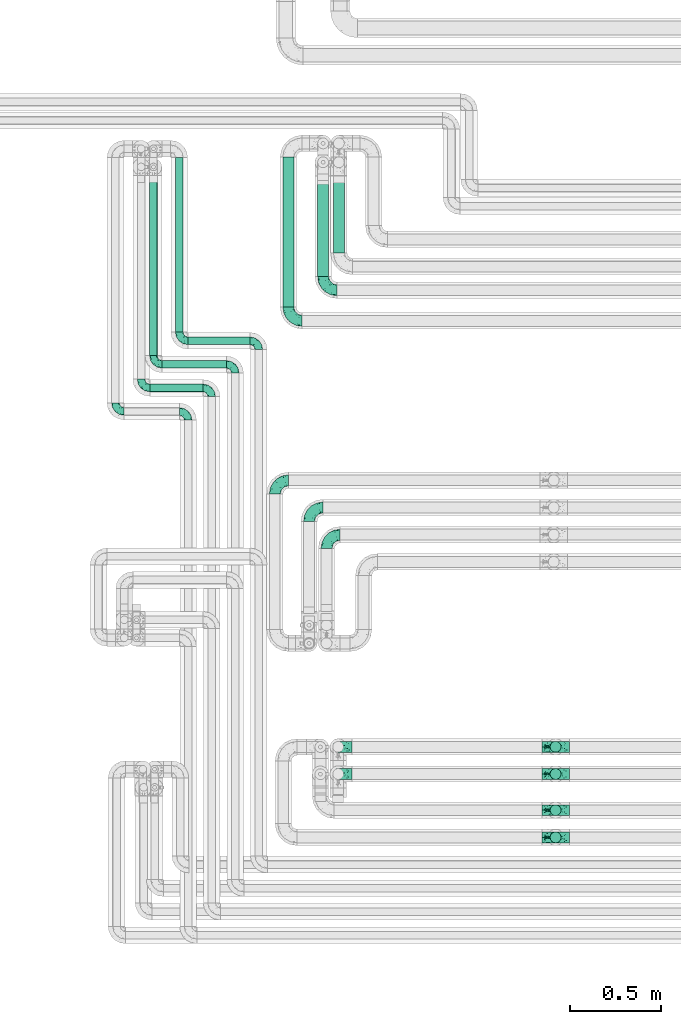
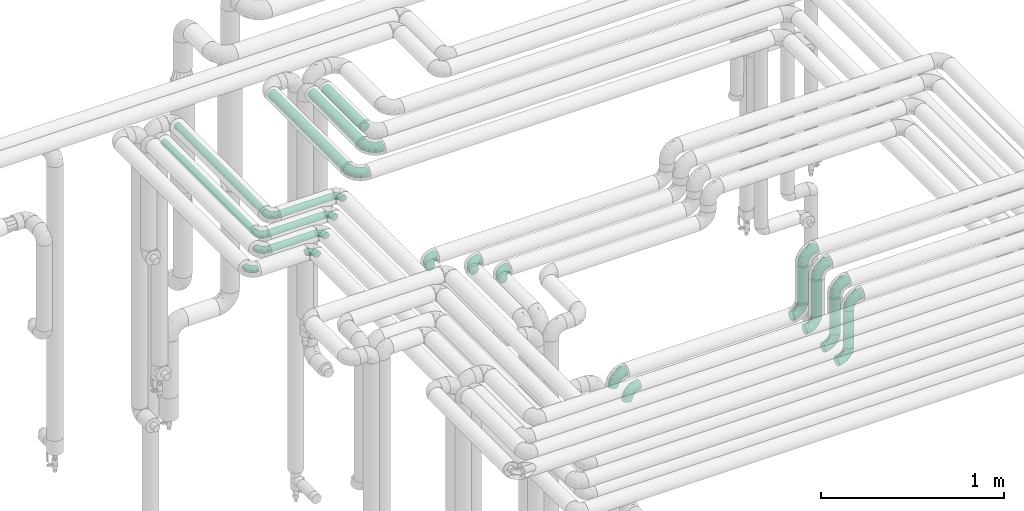
# One storey, part 634 of 827: 23 flow fittings, 12 flow segments.
"""IFC2X3 building model written with IfcOpenShell, lengths in millimetres."""

from ifc_helpers import new_model, entity, si_unit, converted_unit, derived_unit, direction, frame, origin, origin_2d_with_axis, place, context, subcontext, project, spatial, circle, extrude, faceted_brep, source, transform, mapped, material, type_object, type_shapes, element, save


model = new_model("IFC2X3")

# Units and contexts
model_context = context("Model", 3, precision=0.01, world=origin(), true_north=direction((6.12303176911189e-17, 1.0)))
body_context = subcontext(model_context, "Body", "Model", "MODEL_VIEW")
ifc_project = project(units=[si_unit("LENGTHUNIT", "METRE", prefix="MILLI"), si_unit("AREAUNIT", "SQUARE_METRE"), si_unit("VOLUMEUNIT", "CUBIC_METRE"), converted_unit("PLANEANGLEUNIT", "DEGREE", entity("IfcRatioMeasure", 0.0174532925199433), si_unit("PLANEANGLEUNIT", "RADIAN"), dimensions=[0, 0, 0, 0, 0, 0, 0]), si_unit("MASSUNIT", "GRAM", prefix="KILO"), derived_unit("MASSDENSITYUNIT", [(si_unit("MASSUNIT", "GRAM", prefix="KILO"), 1), (si_unit("LENGTHUNIT", "METRE"), -3)]), derived_unit("MOMENTOFINERTIAUNIT", [(si_unit("LENGTHUNIT", "METRE"), 4)]), si_unit("TIMEUNIT", "SECOND"), si_unit("FREQUENCYUNIT", "HERTZ"), si_unit("THERMODYNAMICTEMPERATUREUNIT", "DEGREE_CELSIUS"), derived_unit("THERMALTRANSMITTANCEUNIT", [(si_unit("MASSUNIT", "GRAM", prefix="KILO"), 1), (si_unit("THERMODYNAMICTEMPERATUREUNIT", "KELVIN"), -1), (si_unit("TIMEUNIT", "SECOND"), -3)]), derived_unit("VOLUMETRICFLOWRATEUNIT", [(si_unit("LENGTHUNIT", "METRE"), 3), (si_unit("TIMEUNIT", "SECOND"), -1)]), derived_unit("MASSFLOWRATEUNIT", [(si_unit("MASSUNIT", "GRAM", prefix="KILO"), 1), (si_unit("TIMEUNIT", "SECOND"), -1)]), derived_unit("ROTATIONALFREQUENCYUNIT", [(si_unit("TIMEUNIT", "SECOND"), -1)]), si_unit("ELECTRICCURRENTUNIT", "AMPERE"), si_unit("ELECTRICVOLTAGEUNIT", "VOLT"), si_unit("POWERUNIT", "WATT"), si_unit("FORCEUNIT", "NEWTON", prefix="KILO"), si_unit("ILLUMINANCEUNIT", "LUX"), si_unit("LUMINOUSFLUXUNIT", "LUMEN"), si_unit("LUMINOUSINTENSITYUNIT", "CANDELA"), derived_unit("USERDEFINED", [(si_unit("MASSUNIT", "GRAM", prefix="KILO"), -1), (si_unit("LENGTHUNIT", "METRE"), -2), (si_unit("TIMEUNIT", "SECOND"), 3), (si_unit("LUMINOUSFLUXUNIT", "LUMEN"), 1)]), derived_unit("LINEARVELOCITYUNIT", [(si_unit("LENGTHUNIT", "METRE"), 1), (si_unit("TIMEUNIT", "SECOND"), -1)]), si_unit("PRESSUREUNIT", "PASCAL"), derived_unit("USERDEFINED", [(si_unit("LENGTHUNIT", "METRE"), -2), (si_unit("MASSUNIT", "GRAM", prefix="KILO"), 1), (si_unit("TIMEUNIT", "SECOND"), -2)]), derived_unit("LINEARFORCEUNIT", [(si_unit("MASSUNIT", "GRAM", prefix="KILO"), 1), (si_unit("LENGTHUNIT", "METRE"), 1), (si_unit("TIMEUNIT", "SECOND"), -2), (si_unit("LENGTHUNIT", "METRE"), -1)]), derived_unit("PLANARFORCEUNIT", [(si_unit("MASSUNIT", "GRAM", prefix="KILO"), 1), (si_unit("LENGTHUNIT", "METRE"), 1), (si_unit("TIMEUNIT", "SECOND"), -2), (si_unit("LENGTHUNIT", "METRE"), -2)])], contexts=[model_context])

# Site, building, storey
site_placement = place(None, origin())
site = spatial("IfcSite", under=ifc_project, at=site_placement, CompositionType="ELEMENT")
building_placement = place(site_placement, origin())
building = spatial("IfcBuilding", under=site, at=building_placement, CompositionType="ELEMENT")
storey_placement = place(building_placement, frame((0.0, 0.0, 28200.0)))
storey = spatial("IfcBuildingStorey", under=building, at=storey_placement, Name="08", CompositionType="ELEMENT", Elevation=28200.0)

# Flow segments
pipe_segment_type = type_object("IfcPipeSegmentType", PredefinedType="NOTDEFINED")
flow_segment_1_placement = place(storey_placement, frame((30915.6, 17358.46, 2977.25)))
element("IfcFlowSegment", 1, at=flow_segment_1_placement, inside=storey, type_object=pipe_segment_type, context=body_context, shape_type="SweptSolid", body=[
    extrude(circle(Radius=21.15, at=origin_2d_with_axis()), frame((0.0, 22.75, 22.75), z_axis=(1.0, 0.0, 0.0), x_axis=(0.0, -1.0, 0.0)), (0.0, 0.0, 1.0), 342.918088784113),
])
flow_segment_2_placement = place(storey_placement, frame((31438.07, 17567.2, 2968.4)))
element("IfcFlowSegment", 2, at=flow_segment_2_placement, inside=storey, type_object=pipe_segment_type, context=body_context, shape_type="SweptSolid", body=[
    extrude(circle(Radius=30.0, at=origin_2d_with_axis()), frame((31.6, 0.0, 31.6), z_axis=(0.0, 1.0, 0.0), x_axis=(1.0, 0.0, 0.0)), (0.0, 0.0, 1.0), 828.00000018509),
])
flow_segment_3_placement = place(storey_placement, frame((30773.07, 17228.46, 2977.25)))
element("IfcFlowSegment", 3, at=flow_segment_3_placement, inside=storey, type_object=pipe_segment_type, context=body_context, shape_type="SweptSolid", body=[
    extrude(circle(Radius=21.15, at=origin_2d_with_axis()), frame((0.0, 22.75, 22.75), z_axis=(1.0, 0.0, 0.0), x_axis=(0.0, -1.0, 0.0)), (0.0, 0.0, 1.0), 355.449929999979),
])
flow_segment_4_placement = place(storey_placement, frame((30705.05, 17098.46, 2977.25)))
element("IfcFlowSegment", 4, at=flow_segment_4_placement, inside=storey, type_object=pipe_segment_type, context=body_context, shape_type="SweptSolid", body=[
    extrude(circle(Radius=21.15, at=origin_2d_with_axis()), frame((0.0, 22.75, 22.75), z_axis=(1.0, 0.0, 0.0), x_axis=(0.0, -1.0, 0.0)), (0.0, 0.0, 1.0), 293.47319999997),
])
flow_segment_5_placement = place(storey_placement, frame((30844.86, 17429.2, 2977.25)))
element("IfcFlowSegment", 5, at=flow_segment_5_placement, inside=storey, type_object=pipe_segment_type, context=body_context, shape_type="SweptSolid", body=[
    extrude(circle(Radius=21.15, at=origin_2d_with_axis()), frame((22.75, 0.0, 22.75), z_axis=(0.0, 1.0, 0.0), x_axis=(1.0, 0.0, 0.0)), (0.0, 0.0, 1.0), 963.999999953802),
])
flow_segment_6_placement = place(storey_placement, frame((30702.33, 17299.2, 2977.25)))
element("IfcFlowSegment", 6, at=flow_segment_6_placement, inside=storey, type_object=pipe_segment_type, context=body_context, shape_type="SweptSolid", body=[
    extrude(circle(Radius=21.15, at=origin_2d_with_axis()), frame((22.75, 0.0, 22.75), z_axis=(0.0, 1.0, 0.0), x_axis=(-1.0, 0.0, 0.0)), (0.0, 0.0, 1.0), 993.999999999995),
])
flow_segment_7_placement = place(storey_placement, frame((31630.07, 17736.2, 2968.4)))
element("IfcFlowSegment", 7, at=flow_segment_7_placement, inside=storey, type_object=pipe_segment_type, context=body_context, shape_type="SweptSolid", body=[
    extrude(circle(Radius=30.0, at=origin_2d_with_axis()), frame((31.6, 0.0, 31.6), z_axis=(0.0, 1.0, 0.0), x_axis=(1.0, 0.0, 0.0)), (0.0, 0.0, 1.0), 554.746270361103),
])
flow_segment_8_placement = place(storey_placement, frame((31717.07, 17867.2, 2968.4)))
element("IfcFlowSegment", 8, at=flow_segment_8_placement, inside=storey, type_object=pipe_segment_type, context=body_context, shape_type="SweptSolid", body=[
    extrude(circle(Radius=30.0, at=origin_2d_with_axis()), frame((31.6, 0.0, 31.6), z_axis=(0.0, 1.0, 0.0), x_axis=(1.0, 0.0, 0.0)), (0.0, 0.0, 1.0), 423.74627954619),
])
for number, where in (
    (9, (32913.44, 15108.41, 3076.0)),
    (10, (32913.44, 14958.41, 3076.0)),
    (11, (32913.44, 14758.41, 3076.0)),
):
    element("IfcFlowSegment", number, at=place(storey_placement, frame(where)), inside=storey, type_object=pipe_segment_type, context=body_context, shape_type="SweptSolid", body=[
        extrude(circle(Radius=30.0, at=origin_2d_with_axis()), frame((31.6, 31.6, 0.0)), (0.0, 0.0, 1.0), 248.000000000013),
    ])
flow_segment_9_placement = place(storey_placement, frame((32913.44, 14608.41, 3076.0)))
element("IfcFlowSegment", 12, at=flow_segment_9_placement, inside=storey, type_object=pipe_segment_type, context=body_context, shape_type="SweptSolid", body=[
    extrude(circle(Radius=30.0, at=origin_2d_with_axis()), frame((31.6, 31.6, 0.0)), (0.0, 0.0, 1.0), 248.000000000022),
])

# Flow fittings
ifc_material = material()
pipe_fitting_type_1 = type_object("IfcPipeFittingType", Name="ADSK_1", PredefinedType="NOTDEFINED", material=ifc_material)
shared_shape_1 = source(origin(), body_context, "Body", "Brep", [
    faceted_brep([(-48.0, 10.6, -18.36), (-48.0, 5.49, -20.48), (-48.0, 0.0, -21.2), (-48.0, -5.49, -20.48), (-48.0, -10.6, -18.36), (-48.0, -14.99, -14.99), (-48.0, -18.36, -10.6), (-48.0, -20.48, -5.49), (-48.0, -21.2, 0.0), (-48.0, -20.48, 5.49), (-48.0, -18.36, 10.6), (-48.0, -14.99, 14.99), (-48.0, -10.6, 18.36), (-48.0, -5.49, 20.48), (-48.0, 0.0, 21.2), (-48.0, 5.49, 20.48), (-48.0, 10.6, 18.36), (-48.0, 14.99, 14.99), (-48.0, 18.36, 10.6), (-48.0, 20.48, 5.49), (-48.0, 21.2, 0.0), (-48.0, 20.48, -5.49), (-48.0, 18.36, -10.6), (-48.0, 14.99, -14.99), (0.0, 48.0, -21.2), (-5.49, 48.0, -20.48), (-10.6, 48.0, -18.36), (-14.99, 48.0, -14.99), (-18.36, 48.0, -10.6), (-20.48, 48.0, -5.49), (-21.2, 48.0, 0.0), (-20.48, 48.0, 5.49), (-18.36, 48.0, 10.6), (-14.99, 48.0, 14.99), (-10.6, 48.0, 18.36), (-5.49, 48.0, 20.48), (0.0, 48.0, 21.2), (5.49, 48.0, 20.48), (10.6, 48.0, 18.36), (14.99, 48.0, 14.99), (18.36, 48.0, 10.6), (20.48, 48.0, 5.49), (21.2, 48.0, 0.0), (20.48, 48.0, -5.49), (18.36, 48.0, -10.6), (14.99, 48.0, -14.99), (10.6, 48.0, -18.36), (5.49, 48.0, -20.48), (-35.25, -16.22, 12.01), (-34.76, -18.57, 0.0), (-20.87, -12.37, 10.9), (-31.49, -11.78, 15.9), (-37.0, -2.58, 20.86), (-33.89, 3.62, 21.15), (-31.81, -18.14, 6.76), (-5.78, 5.78, 17.67), (-19.42, -4.1, 17.86), (-9.6, -3.39, 13.73), (-35.44, -7.73, 19.13), (11.78, 31.49, 15.9), (-5.93, -5.46, 6.95), (-18.45, -13.78, 5.46), (-10.29, -8.43, 0.0), (-24.6, 0.55, 20.62), (-37.28, 17.94, 13.81), (-33.38, 22.85, 9.59), (-41.46, 20.06, 8.75), (-29.51, 20.45, 15.16), (-15.04, 10.79, 21.13), (-7.08, 16.98, 20.93), (-8.39, 23.51, 21.15), (-40.86, 13.03, 17.26), (-8.05, 41.26, 19.83), (-3.21, 35.97, 21.14), (8.53, 19.66, 14.74), (4.1, 19.42, 17.86), (-37.72, 22.66, 4.78), (-37.07, 8.58, 19.98), (-13.0, 5.43, 19.97), (-3.78, 13.93, 19.7), (3.02, 8.69, 13.43), (-2.27, -0.05, 10.65), (6.22, 6.99, 7.09), (-22.25, 34.6, 9.45), (18.14, 31.81, 6.76), (16.22, 35.25, 12.01), (12.37, 20.87, 10.9), (7.73, 35.44, 19.13), (-21.52, -15.93, 0.0), (2.58, 37.0, 20.86), (18.57, 34.76, 0.0), (13.78, 18.45, 5.46), (15.93, 21.52, 0.0), (-20.03, -8.54, 14.9), (-28.6, 28.6, 5.16), (-24.79, 34.6, 0.0), (-34.6, 24.79, 0.0), (-22.81, 37.41, 4.68), (-23.36, 26.33, 14.79), (-13.68, 37.05, 17.49), (-17.72, 38.12, 13.73), (-26.25, 27.3, 11.24), (-9.71, 32.34, 20.14), (-17.26, 25.6, 18.71), (-26.33, 9.99, 20.77), (-24.06, 6.05, 21.2), (-25.02, 15.46, 19.56), (-24.3, 20.72, 17.57), (-31.95, 15.23, 17.8), (-13.53, 24.7, 20.21), (-17.6, 17.6, 20.6), (-0.55, 24.6, 20.62), (-11.41, -7.48, 10.43), (0.93, -0.93, 0.0), (8.43, 10.29, 0.0), (-11.41, -7.48, -10.43), (-20.1, -8.84, -14.66), (-9.6, -3.39, -13.73), (7.73, 35.44, -19.13), (4.1, 19.42, -17.86), (-0.55, 24.6, -20.62), (-38.12, 17.72, -13.73), (-37.05, 13.68, -17.49), (-32.34, 9.71, -20.14), (-41.26, 8.05, -19.83), (-37.41, 22.81, -4.68), (-23.51, 8.39, -21.15), (-35.97, 3.21, -21.14), (-28.6, 28.6, -5.16), (-31.81, -18.14, -6.76), (-18.45, -13.78, -5.46), (-25.6, 17.26, -18.71), (-19.42, -4.1, -17.86), (-17.94, 37.28, -13.81), (-22.85, 33.38, -9.59), (-20.06, 41.46, -8.75), (-31.49, -11.78, -15.9), (-35.25, -16.22, -12.01), (8.53, 19.66, -14.74), (11.78, 31.49, -15.9), (-9.99, 26.33, -20.77), (-6.05, 24.06, -21.2), (-10.79, 15.04, -21.13), (-37.0, -2.58, -20.86), (-16.98, 7.08, -20.93), (-5.43, 13.0, -19.97), (-13.93, 3.78, -19.7), (-20.87, -12.37, -10.9), (-26.33, 23.36, -14.79), (-22.66, 37.72, -4.78), (13.78, 18.45, -5.46), (18.14, 31.81, -6.76), (-15.46, 25.02, -19.56), (-20.72, 24.3, -17.57), (16.22, 35.25, -12.01), (-13.03, 40.86, -17.26), (-8.58, 37.07, -19.98), (2.58, 37.0, -20.86), (-3.62, 33.89, -21.15), (-34.6, 22.25, -9.45), (6.22, 6.99, -7.09), (-20.45, 29.51, -15.16), (-35.44, -7.73, -19.13), (12.37, 20.87, -10.9), (-27.3, 26.25, -11.24), (-15.23, 31.95, -17.8), (-24.7, 13.53, -20.21), (-24.6, 0.55, -20.62), (-5.78, 5.78, -17.67), (-17.6, 17.6, -20.6), (3.02, 8.69, -13.43), (-5.93, -5.46, -6.95), (-2.27, -0.05, -10.65)], [[[0, 1, 2, 3, 4, 5, 6, 7, 8, 9, 10, 11, 12, 13, 14, 15, 16, 17, 18, 19, 20, 21, 22, 23]], [[24, 25, 26, 27, 28, 29, 30, 31, 32, 33, 34, 35, 36, 37, 38, 39, 40, 41, 42, 43, 44, 45, 46, 47]], [[10, 48, 11]], [[9, 8, 49]], [[48, 50, 51]], [[14, 52, 53]], [[10, 54, 48]], [[9, 54, 10]], [[55, 56, 57]], [[51, 12, 11]], [[51, 58, 12]], [[59, 39, 38]], [[60, 61, 62]], [[58, 56, 63]], [[64, 65, 66]], [[67, 65, 64]], [[68, 69, 70]], [[16, 71, 17]], [[13, 52, 14]], [[35, 72, 73]], [[14, 53, 15]], [[17, 64, 18]], [[74, 59, 75]], [[20, 19, 76]], [[66, 19, 18]], [[77, 15, 53]], [[15, 77, 16]], [[69, 78, 79]], [[80, 81, 82]], [[32, 31, 83]], [[84, 85, 86]], [[59, 87, 75]], [[61, 54, 88]], [[36, 89, 37]], [[84, 41, 40]], [[36, 35, 73]], [[90, 41, 84]], [[40, 39, 85]], [[12, 58, 13]], [[85, 84, 40]], [[91, 84, 86]], [[84, 92, 90]], [[87, 38, 37]], [[93, 56, 51]], [[65, 94, 76]], [[94, 95, 96]], [[84, 91, 92]], [[95, 97, 30]], [[98, 99, 100]], [[76, 94, 96]], [[101, 98, 83]], [[100, 99, 33]], [[102, 70, 73]], [[103, 102, 99]], [[94, 97, 95]], [[72, 99, 102]], [[72, 35, 34]], [[34, 33, 99]], [[9, 49, 54]], [[87, 59, 38]], [[104, 105, 68]], [[106, 103, 107]], [[106, 77, 104]], [[71, 64, 17]], [[108, 107, 67]], [[33, 32, 100]], [[109, 103, 110]], [[102, 109, 70]], [[89, 73, 111]], [[50, 48, 54]], [[51, 11, 48]], [[56, 58, 51]], [[88, 54, 49]], [[52, 58, 63]], [[50, 112, 93]], [[56, 55, 78]], [[39, 59, 85]], [[86, 85, 59]], [[89, 87, 37]], [[42, 41, 90]], [[111, 79, 75]], [[111, 75, 87]], [[75, 55, 80]], [[104, 77, 53]], [[71, 77, 108]], [[32, 83, 100]], [[98, 100, 83]], [[99, 98, 103]], [[106, 107, 108]], [[68, 70, 110]], [[111, 73, 70]], [[68, 110, 104]], [[68, 63, 78]], [[57, 93, 112]], [[80, 55, 57]], [[61, 50, 54]], [[80, 82, 86]], [[81, 57, 112]], [[74, 86, 59]], [[60, 113, 82]], [[82, 114, 91]], [[101, 94, 65]], [[97, 94, 83]], [[73, 89, 36]], [[87, 89, 111]], [[58, 52, 13]], [[53, 52, 63]], [[104, 53, 105]], [[106, 104, 110]], [[20, 76, 96]], [[76, 19, 66]], [[103, 106, 110]], [[77, 106, 108]], [[103, 98, 107]], [[67, 107, 98]], [[67, 98, 101]], [[108, 67, 64]], [[53, 63, 105]], [[63, 68, 105]], [[83, 31, 97]], [[30, 97, 31]], [[62, 113, 60]], [[112, 61, 60]], [[61, 88, 62]], [[86, 82, 91]], [[56, 78, 63]], [[114, 82, 113]], [[114, 92, 91]], [[79, 78, 55]], [[75, 79, 55]], [[69, 79, 111]], [[70, 69, 111]], [[78, 69, 68]], [[77, 71, 16]], [[64, 71, 108]], [[64, 66, 18]], [[76, 66, 65]], [[99, 72, 34]], [[73, 72, 102]], [[94, 101, 83]], [[67, 101, 65]], [[75, 80, 74]], [[80, 86, 74]], [[70, 109, 110]], [[102, 103, 109]], [[50, 93, 51]], [[57, 56, 93]], [[61, 112, 50]], [[81, 112, 60]], [[82, 81, 60]], [[80, 57, 81]], [[115, 116, 117]], [[118, 119, 120]], [[121, 122, 23]], [[123, 124, 122]], [[96, 125, 20]], [[123, 126, 127]], [[128, 96, 95]], [[129, 130, 88]], [[123, 122, 131]], [[116, 132, 117]], [[133, 134, 135]], [[0, 124, 1]], [[5, 136, 137]], [[138, 119, 139]], [[129, 88, 49]], [[140, 141, 142]], [[6, 5, 137]], [[46, 118, 47]], [[143, 3, 2]], [[144, 145, 146]], [[6, 129, 7]], [[129, 137, 147]], [[127, 2, 1]], [[148, 122, 121]], [[128, 125, 96]], [[134, 128, 149]], [[95, 149, 128]], [[150, 151, 92]], [[30, 29, 149]], [[152, 131, 153]], [[27, 133, 28]], [[154, 45, 44]], [[136, 5, 4]], [[27, 26, 155]], [[156, 26, 25]], [[24, 157, 158]], [[24, 47, 157]], [[22, 21, 159]], [[160, 150, 114]], [[134, 133, 161]], [[142, 144, 126]], [[46, 139, 118]], [[162, 136, 4]], [[156, 25, 158]], [[1, 124, 127]], [[115, 147, 116]], [[45, 154, 139]], [[139, 46, 45]], [[154, 163, 139]], [[162, 4, 3]], [[42, 90, 43]], [[130, 129, 147]], [[49, 7, 129]], [[43, 151, 44]], [[0, 23, 122]], [[24, 158, 25]], [[136, 162, 132]], [[135, 29, 28]], [[43, 90, 151]], [[164, 148, 159]], [[152, 156, 140]], [[155, 133, 27]], [[165, 153, 161]], [[23, 22, 121]], [[123, 131, 166]], [[123, 166, 126]], [[143, 127, 167]], [[147, 137, 136]], [[8, 7, 49]], [[129, 6, 137]], [[143, 162, 3]], [[167, 146, 132]], [[167, 132, 162]], [[132, 168, 117]], [[44, 151, 154]], [[92, 151, 90]], [[163, 154, 151]], [[119, 118, 139]], [[157, 118, 120]], [[138, 139, 163]], [[119, 168, 145]], [[140, 156, 158]], [[155, 156, 165]], [[22, 159, 121]], [[148, 121, 159]], [[122, 148, 131]], [[152, 153, 165]], [[142, 126, 169]], [[167, 127, 126]], [[142, 169, 140]], [[142, 120, 145]], [[168, 170, 117]], [[160, 171, 172]], [[115, 172, 171]], [[171, 62, 130]], [[119, 170, 168]], [[170, 163, 160]], [[150, 163, 151]], [[113, 171, 160]], [[164, 128, 134]], [[125, 128, 159]], [[127, 143, 2]], [[162, 143, 167]], [[118, 157, 47]], [[158, 157, 120]], [[140, 158, 141]], [[152, 140, 169]], [[30, 149, 95]], [[149, 29, 135]], [[131, 152, 169]], [[156, 152, 165]], [[131, 148, 153]], [[161, 153, 148]], [[161, 148, 164]], [[165, 161, 133]], [[158, 120, 141]], [[120, 142, 141]], [[159, 21, 125]], [[20, 125, 21]], [[115, 130, 147]], [[114, 113, 160]], [[62, 171, 113]], [[62, 88, 130]], [[160, 163, 150]], [[150, 92, 114]], [[119, 145, 120]], [[146, 145, 168]], [[132, 146, 168]], [[144, 146, 167]], [[126, 144, 167]], [[145, 144, 142]], [[156, 155, 26]], [[133, 155, 165]], [[133, 135, 28]], [[149, 135, 134]], [[122, 124, 0]], [[127, 124, 123]], [[128, 164, 159]], [[161, 164, 134]], [[163, 170, 138]], [[170, 119, 138]], [[131, 169, 166]], [[126, 166, 169]], [[147, 136, 116]], [[132, 116, 136]], [[172, 115, 117]], [[130, 115, 171]], [[117, 170, 172]], [[160, 172, 170]]]),
])
type_shapes(pipe_fitting_type_1, [shared_shape_1])
for number, where, z_axis, x_axis, name in (
    (13, (30867.6, 17381.2, 3000.0), (0.0, 0.0, 1.0), (0.0, -1.0, 0.0), "ADSK_1"),
    (14, (31176.52, 17251.2, 3000.0), (0.0, 0.0, 1.0), (0.0, 1.0, 0.0), "ADSK_1"),
    (15, (30657.05, 17121.2, 3000.0), (0.0, 0.0, 1.0), (0.0, -1.0, 0.0), "ADSK_1"),
    (16, (31046.52, 17121.2, 3000.0), (0.0, 0.0, 1.0), (0.0, 1.0, 0.0), "ADSK_1"),
    (17, (30515.05, 16991.2, 3000.0), (0.0, 0.0, 1.0), (0.0, -1.0, 0.0), "ADSK_1"),
    (18, (30916.52, 16991.2, 3000.0), (0.0, 0.0, 1.0), (0.0, 1.0, 0.0), "ADSK_1"),
    (19, (30725.07, 17251.2, 3000.0), (0.0, 0.0, 1.0), (0.0, -1.0, 0.0), "ADSK_1"),
    (20, (31306.52, 17381.2, 3000.0), (0.0, 0.0, 1.0), (0.0, 1.0, 0.0), "ADSK_1"),
):
    element("IfcFlowFitting", number, at=place(storey_placement, frame(where, z_axis=z_axis, x_axis=x_axis)), inside=storey, type_object=pipe_fitting_type_1, material=ifc_material, Name=name, ObjectType="ADSK_1", context=body_context, shape_type="MappedRepresentation", body=[
        mapped(shared_shape_1, transform((0.0, 0.0, 0.0), scale=1.0)),
    ])
pipe_fitting_type_2 = type_object("IfcPipeFittingType", Name="ADSK_1", PredefinedType="NOTDEFINED", material=ifc_material)
shared_shape_2 = source(origin(), body_context, "Body", "Brep", [
    faceted_brep([(-76.0, 15.07, -26.11), (-76.0, 7.8, -29.12), (-76.0, 0.0, -30.15), (-76.0, -7.8, -29.12), (-76.0, -15.08, -26.11), (-76.0, -21.32, -21.32), (-76.0, -26.11, -15.08), (-76.0, -29.12, -7.8), (-76.0, -30.15, 0.0), (-76.0, -29.12, 7.8), (-76.0, -26.11, 15.07), (-76.0, -21.32, 21.32), (-76.0, -15.08, 26.11), (-76.0, -7.8, 29.12), (-76.0, 0.0, 30.15), (-76.0, 7.8, 29.12), (-76.0, 15.07, 26.11), (-76.0, 21.32, 21.32), (-76.0, 26.11, 15.07), (-76.0, 29.12, 7.8), (-76.0, 30.15, 0.0), (-76.0, 29.12, -7.8), (-76.0, 26.11, -15.08), (-76.0, 21.32, -21.32), (0.0, 76.0, -30.15), (-7.8, 76.0, -29.12), (-15.07, 76.0, -26.11), (-21.32, 76.0, -21.32), (-26.11, 76.0, -15.08), (-29.12, 76.0, -7.8), (-30.15, 76.0, 0.0), (-29.12, 76.0, 7.8), (-26.11, 76.0, 15.07), (-21.32, 76.0, 21.32), (-15.07, 76.0, 26.11), (-7.8, 76.0, 29.12), (0.0, 76.0, 30.15), (7.8, 76.0, 29.12), (15.08, 76.0, 26.11), (21.32, 76.0, 21.32), (26.11, 76.0, 15.07), (29.12, 76.0, 7.8), (30.15, 76.0, 0.0), (29.12, 76.0, -7.8), (26.11, 76.0, -15.08), (21.32, 76.0, -21.32), (15.08, 76.0, -26.11), (7.8, 76.0, -29.12), (10.79, 31.43, 21.07), (4.32, 31.7, 25.72), (1.65, 15.19, 19.92), (-61.17, -27.8, 0.0), (-51.1, -25.49, 9.84), (-56.14, -10.61, 27.27), (-31.7, -4.32, 25.72), (-39.75, 1.72, 29.41), (-43.2, -24.95, 0.0), (-1.86, 1.86, 0.0), (4.49, 7.65, 5.78), (-7.82, -4.61, 5.83), (-56.21, -22.79, 17.21), (-58.98, -3.38, 29.7), (-53.96, 5.6, 30.07), (-10.86, 10.86, 25.48), (-17.2, -2.6, 20.44), (-49.15, -16.01, 22.7), (-22.18, -14.24, 7.99), (-28.4, -17.42, 0.0), (-13.61, -9.88, 0.0), (-39.0, 23.48, 27.76), (-58.76, 12.54, 28.36), (-41.61, 15.41, 29.48), (16.01, 49.15, 22.7), (-58.55, 25.93, 19.53), (-51.53, 33.5, 13.51), (-64.92, 28.76, 12.4), (-7.48, 23.14, 28.25), (-1.72, 39.75, 29.41), (-12.04, 27.88, 29.88), (-63.91, 18.81, 24.52), (-11.63, 65.16, 28.18), (-4.97, 57.02, 30.05), (9.88, 13.61, 0.0), (-62.5, 31.74, 5.02), (-45.17, 30.98, 21.2), (-21.78, 9.76, 28.58), (10.61, 56.14, 27.27), (-32.09, 54.42, 13.26), (22.79, 56.21, 17.21), (15.38, 31.17, 15.63), (25.49, 51.1, 9.84), (21.84, 36.35, 5.92), (24.95, 43.2, 0.0), (3.38, 58.98, 29.7), (-31.17, -15.38, 15.63), (-39.39, 41.78, 15.45), (-34.56, 41.13, 20.79), (-39.81, -23.25, 5.49), (27.8, 61.17, 0.0), (-31.74, 62.5, 5.02), (-53.07, 36.29, 0.0), (-42.95, 42.95, 7.29), (-36.29, 53.07, 0.0), (-19.83, 58.51, 24.79), (-25.48, 60.2, 19.41), (-14.53, 50.96, 28.57), (-13.31, 37.09, 30.07), (-26.16, 40.06, 26.4), (-32.43, -10.35, 21.9), (17.42, 28.4, 0.0), (14.24, 22.18, 7.99), (-38.67, 9.72, 30.15), (-24.66, 17.36, 30.09), (-37.08, 31.49, 24.99), (-49.27, 22.83, 25.24), (-20.8, 38.81, 28.63), (-27.58, 27.58, 29.2), (-36.07, -20.23, 10.71), (-15.19, -6.16, 14.9), (6.6, 15.4, 14.49), (-2.51, 2.51, 11.35), (-65.16, 11.63, -28.18), (-49.15, -16.01, -22.7), (-57.02, 4.97, -30.05), (-25.93, 58.55, -19.53), (-33.5, 51.53, -13.51), (-28.76, 64.92, -12.4), (-60.2, 25.48, -19.41), (-58.51, 19.83, -24.79), (4.61, 7.82, -5.83), (-7.65, -4.49, -5.78), (-2.51, 2.51, -11.35), (-62.5, 31.74, -5.02), (-50.96, 14.53, -28.57), (-37.09, 13.31, -30.07), (-42.95, 42.95, -7.29), (25.49, 51.1, -9.84), (22.79, 56.21, -17.21), (-40.06, 26.16, -26.4), (3.38, 58.98, -29.7), (-5.6, 53.96, -30.07), (-27.88, 12.04, -29.88), (-9.76, 21.78, -28.58), (-23.14, 7.48, -28.25), (-51.1, -25.49, -9.84), (15.38, 31.17, -15.63), (16.01, 49.15, -22.7), (-23.48, 39.0, -27.76), (-12.54, 58.76, -28.36), (-15.41, 41.61, -29.48), (-56.21, -22.79, -17.21), (-9.72, 38.67, -30.15), (-17.36, 24.66, -30.09), (-22.18, -14.24, -7.99), (-41.13, 34.56, -20.79), (-31.74, 62.5, -5.02), (-58.98, -3.38, -29.7), (-31.17, -15.38, -15.63), (-56.14, -10.61, -27.27), (14.24, 22.18, -7.99), (23.25, 39.81, -5.49), (-31.49, 37.08, -24.99), (-15.19, -6.16, -14.9), (1.65, 15.19, -19.92), (-18.81, 63.91, -24.52), (-32.59, -11.62, -20.84), (-31.7, -4.32, -25.72), (-17.2, -2.6, -20.44), (-39.75, 1.72, -29.41), (-54.42, 32.09, -13.26), (-30.98, 45.17, -21.2), (10.61, 56.14, -27.27), (10.23, 31.31, -21.52), (4.32, 31.7, -25.72), (-41.78, 39.39, -15.45), (-1.72, 39.75, -29.41), (-36.35, -21.84, -5.92), (-22.83, 49.27, -25.24), (-38.81, 20.8, -28.63), (-27.58, 27.58, -29.2), (-10.86, 10.86, -25.48), (20.23, 36.07, -10.71), (6.6, 15.4, -14.49)], [[[0, 1, 2, 3, 4, 5, 6, 7, 8, 9, 10, 11, 12, 13, 14, 15, 16, 17, 18, 19, 20, 21, 22, 23]], [[24, 25, 26, 27, 28, 29, 30, 31, 32, 33, 34, 35, 36, 37, 38, 39, 40, 41, 42, 43, 44, 45, 46, 47]], [[48, 49, 50]], [[51, 52, 9]], [[53, 54, 55]], [[9, 52, 10]], [[56, 52, 51]], [[57, 58, 59]], [[11, 10, 60]], [[14, 61, 62]], [[63, 54, 64]], [[65, 12, 11]], [[65, 53, 12]], [[66, 67, 68]], [[69, 70, 71]], [[72, 39, 38]], [[73, 74, 75]], [[15, 70, 16]], [[76, 77, 78]], [[16, 79, 17]], [[13, 61, 14]], [[35, 80, 81]], [[14, 62, 15]], [[17, 73, 18]], [[57, 82, 58]], [[20, 19, 83]], [[75, 19, 18]], [[70, 15, 62]], [[73, 84, 74]], [[78, 85, 76]], [[38, 86, 72]], [[32, 31, 87]], [[88, 89, 90]], [[91, 92, 90]], [[72, 86, 49]], [[36, 93, 37]], [[75, 83, 19]], [[36, 35, 81]], [[60, 94, 65]], [[40, 90, 41]], [[95, 96, 87]], [[88, 90, 40]], [[66, 97, 67]], [[90, 98, 41]], [[40, 39, 88]], [[99, 31, 30]], [[20, 83, 100]], [[101, 102, 100]], [[52, 60, 10]], [[102, 99, 30]], [[96, 103, 104]], [[83, 101, 100]], [[12, 53, 13]], [[104, 103, 33]], [[105, 106, 81]], [[107, 105, 103]], [[64, 54, 108]], [[80, 103, 105]], [[80, 35, 34]], [[34, 33, 103]], [[86, 38, 37]], [[109, 110, 82]], [[71, 111, 112]], [[69, 107, 113]], [[79, 73, 17]], [[114, 113, 84]], [[33, 32, 104]], [[115, 107, 116]], [[105, 115, 106]], [[93, 81, 77]], [[54, 53, 65]], [[61, 53, 55]], [[108, 94, 64]], [[54, 63, 85]], [[93, 86, 37]], [[77, 76, 49]], [[77, 49, 86]], [[49, 63, 50]], [[60, 52, 117]], [[65, 11, 60]], [[39, 72, 88]], [[89, 88, 72]], [[71, 70, 62]], [[79, 70, 114]], [[103, 96, 107]], [[69, 113, 114]], [[112, 106, 116]], [[77, 81, 106]], [[112, 116, 71]], [[112, 55, 85]], [[64, 50, 63]], [[57, 59, 68]], [[32, 87, 104]], [[96, 104, 87]], [[94, 118, 64]], [[50, 119, 89]], [[50, 64, 118]], [[50, 89, 48]], [[81, 93, 36]], [[86, 93, 77]], [[53, 61, 13]], [[62, 61, 55]], [[71, 62, 111]], [[69, 71, 116]], [[95, 101, 74]], [[99, 101, 87]], [[118, 66, 59]], [[117, 97, 66]], [[117, 66, 94]], [[91, 89, 110]], [[91, 110, 109]], [[110, 89, 119]], [[9, 8, 51]], [[98, 90, 92]], [[98, 42, 41]], [[101, 83, 74]], [[101, 99, 102]], [[87, 31, 99]], [[62, 55, 111]], [[55, 112, 111]], [[107, 69, 116]], [[70, 69, 114]], [[107, 96, 113]], [[84, 113, 96]], [[84, 96, 95]], [[114, 84, 73]], [[70, 79, 16]], [[73, 79, 114]], [[54, 85, 55]], [[76, 85, 63]], [[49, 76, 63]], [[77, 106, 78]], [[106, 112, 78]], [[85, 78, 112]], [[73, 75, 18]], [[83, 75, 74]], [[103, 80, 34]], [[81, 80, 105]], [[101, 95, 87]], [[84, 95, 74]], [[106, 115, 116]], [[105, 107, 115]], [[120, 59, 58]], [[82, 110, 58]], [[119, 58, 110]], [[118, 59, 120]], [[66, 68, 59]], [[54, 65, 108]], [[94, 108, 65]], [[66, 118, 94]], [[50, 118, 120]], [[50, 120, 119]], [[119, 120, 58]], [[89, 72, 48]], [[49, 48, 72]], [[60, 117, 94]], [[117, 52, 97]], [[52, 56, 97]], [[67, 97, 56]], [[92, 91, 109]], [[89, 91, 90]], [[121, 1, 0]], [[122, 5, 4]], [[2, 1, 123]], [[124, 125, 126]], [[127, 128, 23]], [[129, 130, 131]], [[100, 132, 20]], [[133, 134, 123]], [[135, 100, 102]], [[136, 137, 44]], [[133, 128, 138]], [[24, 139, 140]], [[141, 142, 143]], [[121, 128, 133]], [[6, 144, 7]], [[137, 145, 146]], [[144, 51, 7]], [[147, 148, 149]], [[144, 6, 150]], [[149, 151, 152]], [[153, 68, 67]], [[154, 128, 127]], [[30, 155, 102]], [[43, 42, 98]], [[156, 3, 2]], [[157, 144, 150]], [[158, 4, 3]], [[24, 140, 25]], [[155, 135, 102]], [[159, 160, 109]], [[30, 29, 155]], [[147, 138, 161]], [[27, 124, 28]], [[57, 129, 82]], [[162, 163, 131]], [[27, 26, 164]], [[148, 26, 25]], [[165, 166, 167]], [[24, 47, 139]], [[143, 168, 141]], [[22, 21, 169]], [[125, 124, 170]], [[148, 25, 140]], [[46, 146, 171]], [[158, 122, 4]], [[0, 23, 128]], [[1, 121, 123]], [[109, 82, 159]], [[45, 44, 137]], [[146, 46, 45]], [[136, 43, 98]], [[132, 21, 20]], [[136, 98, 92]], [[172, 173, 146]], [[46, 171, 47]], [[43, 136, 44]], [[174, 154, 169]], [[171, 173, 175]], [[6, 5, 150]], [[126, 29, 28]], [[176, 56, 144]], [[122, 158, 166]], [[164, 124, 27]], [[177, 161, 170]], [[23, 22, 127]], [[178, 138, 179]], [[133, 178, 134]], [[156, 123, 168]], [[156, 158, 3]], [[168, 143, 166]], [[168, 166, 158]], [[166, 180, 167]], [[173, 171, 146]], [[139, 171, 175]], [[172, 145, 163]], [[173, 180, 142]], [[5, 122, 150]], [[157, 150, 122]], [[137, 136, 181]], [[146, 45, 137]], [[149, 148, 140]], [[164, 148, 177]], [[128, 154, 138]], [[147, 161, 177]], [[152, 134, 179]], [[168, 123, 134]], [[152, 179, 149]], [[152, 175, 142]], [[57, 130, 129]], [[157, 165, 167]], [[22, 169, 127]], [[154, 127, 169]], [[163, 167, 180]], [[162, 157, 167]], [[173, 163, 180]], [[182, 163, 145]], [[123, 156, 2]], [[158, 156, 168]], [[171, 139, 47]], [[140, 139, 175]], [[149, 140, 151]], [[147, 149, 179]], [[174, 135, 125]], [[132, 135, 169]], [[176, 157, 153]], [[176, 153, 67]], [[153, 157, 162]], [[182, 159, 129]], [[181, 160, 159]], [[181, 159, 145]], [[51, 144, 56]], [[51, 8, 7]], [[135, 132, 100]], [[169, 21, 132]], [[126, 155, 29]], [[135, 155, 125]], [[140, 175, 151]], [[175, 152, 151]], [[138, 147, 179]], [[148, 147, 177]], [[138, 154, 161]], [[170, 161, 154]], [[170, 154, 174]], [[177, 170, 124]], [[148, 164, 26]], [[124, 164, 177]], [[173, 142, 175]], [[143, 142, 180]], [[166, 143, 180]], [[168, 134, 141]], [[134, 152, 141]], [[142, 141, 152]], [[124, 126, 28]], [[155, 126, 125]], [[128, 121, 0]], [[123, 121, 133]], [[135, 174, 169]], [[170, 174, 125]], [[134, 178, 179]], [[133, 138, 178]], [[130, 153, 162]], [[68, 153, 130]], [[57, 68, 130]], [[182, 129, 131]], [[159, 82, 129]], [[157, 122, 165]], [[166, 165, 122]], [[163, 162, 167]], [[162, 131, 130]], [[145, 172, 146]], [[163, 173, 172]], [[159, 182, 145]], [[131, 163, 182]], [[56, 176, 67]], [[157, 176, 144]], [[137, 181, 145]], [[181, 136, 160]], [[136, 92, 160]], [[109, 160, 92]]]),
])
type_shapes(pipe_fitting_type_2, [shared_shape_2])
for number, where, z_axis, x_axis, name in (
    (21, (31469.66, 17491.2, 3000.0), (0.0, 0.0, 1.0), (0.0, -1.0, 0.0), "ADSK_1"),
    (22, (31661.66, 17660.2, 3000.0), (0.0, 0.0, 1.0), (0.0, -1.0, 0.0), "ADSK_1"),
    (23, (32945.03, 15140.0, 3400.0), (0.0, -1.0, 0.0), (-1.0, 0.0, 0.0), "ADSK_1"),
    (24, (32945.03, 14990.0, 3400.0), (0.0, -1.0, 0.0), (-1.0, 0.0, 0.0), "ADSK_1"),
    (25, (32945.03, 14790.0, 3400.0), (0.0, -1.0, 0.0), (-1.0, 0.0, 0.0), "ADSK_1"),
    (26, (32945.03, 14640.0, 3400.0), (0.0, -1.0, 0.0), (-1.0, 0.0, 0.0), "ADSK_1"),
    (27, (32945.03, 14640.0, 3000.0), (0.0, 1.0, 0.0), (0.0, 0.0, -1.0), "ADSK_1"),
    (28, (32945.03, 15140.0, 3000.0), (0.0, 1.0, 0.0), (0.0, 0.0, -1.0), "ADSK_1"),
    (29, (31680.25, 16311.2, 3000.0), (0.0, 0.0, 1.0), (-1.0, 0.0, 0.0), "ADSK_1"),
    (30, (31584.25, 16461.2, 3000.0), (0.0, 0.0, 1.0), (-1.0, 0.0, 0.0), "ADSK_1"),
    (31, (31395.03, 16611.2, 3000.0), (0.0, 0.0, 1.0), (-1.0, 0.0, 0.0), "ADSK_1"),
    (32, (32945.03, 14790.0, 3000.0), (0.0, 1.0, 0.0), (0.0, 0.0, -1.0), "ADSK_1"),
    (33, (31745.03, 15140.0, 3000.0), (0.0, -1.0, 0.0), (-1.0, 0.0, 0.0), "ADSK_1"),
    (34, (32945.03, 14990.0, 3000.0), (0.0, 1.0, 0.0), (0.0, 0.0, -1.0), "ADSK_1"),
    (35, (31745.03, 14990.0, 3000.0), (0.0, 1.0, 0.0), (0.0, 0.0, 1.0), "ADSK_1"),
):
    element("IfcFlowFitting", number, at=place(storey_placement, frame(where, z_axis=z_axis, x_axis=x_axis)), inside=storey, type_object=pipe_fitting_type_2, material=ifc_material, Name=name, ObjectType="ADSK_1", context=body_context, shape_type="MappedRepresentation", body=[
        mapped(shared_shape_2, transform((0.0, 0.0, 0.0), scale=1.0)),
    ])

save(model, "model.ifc")
